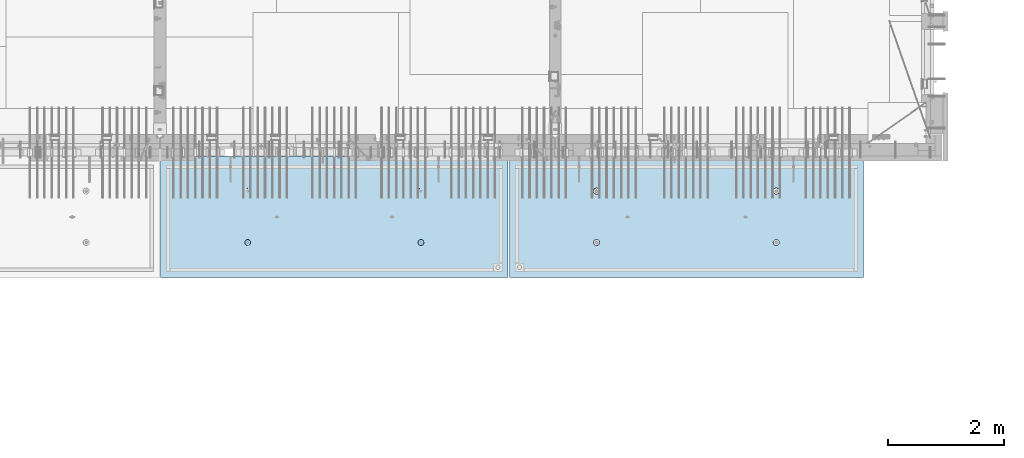
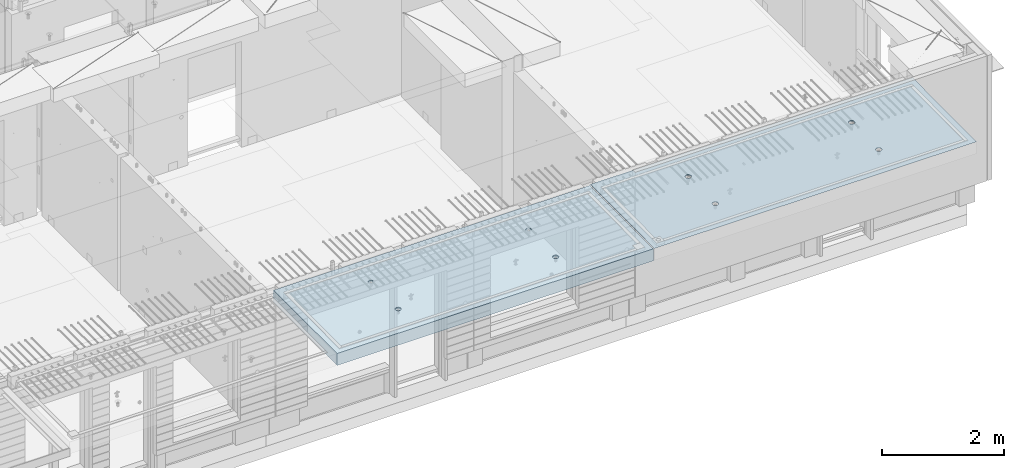
# One storey, part 181 of 325: 2 slabs, 2 elements without a shape of their own.
"""IFC2X3 building model written with IfcOpenShell, lengths in millimetres."""

from ifc_helpers import new_model, si_unit, frame, origin_with_axes, place, context, subcontext, project, spatial, faceted_brep, material, type_object, element, aggregate, save


model = new_model("IFC2X3")

# Units and contexts
model_context = context("Model", 3, precision=1e-05, world=origin_with_axes())
body_context = subcontext(model_context, "Body", "Model", "MODEL_VIEW")
ifc_project = project(units=[si_unit("LENGTHUNIT", "METRE", prefix="MILLI"), si_unit("AREAUNIT", "SQUARE_METRE"), si_unit("VOLUMEUNIT", "CUBIC_METRE"), si_unit("MASSUNIT", "GRAM", prefix="KILO"), si_unit("TIMEUNIT", "SECOND"), si_unit("PLANEANGLEUNIT", "RADIAN"), si_unit("SOLIDANGLEUNIT", "STERADIAN"), si_unit("THERMODYNAMICTEMPERATUREUNIT", "DEGREE_CELSIUS"), si_unit("LUMINOUSINTENSITYUNIT", "LUMEN")], contexts=[model_context])

# Site, building, storey
site_placement = place(None, origin_with_axes())
site = spatial("IfcSite", under=ifc_project, at=site_placement, CompositionType="ELEMENT")
building_placement = place(site_placement, origin_with_axes())
building = spatial("IfcBuilding", under=site, at=building_placement, CompositionType="ELEMENT")
storey_placement = place(building_placement, origin_with_axes())
storey = spatial("IfcBuildingStorey", under=building, at=storey_placement, Name="1", CompositionType="ELEMENT", Elevation=0.0)

# Assembly, slab
assembly_1_placement = place(storey_placement, origin_with_axes())
assembly_1 = element("IfcElementAssembly", 1, at=assembly_1_placement, inside=storey, AssemblyPlace="NOTDEFINED", PredefinedType="REINFORCEMENT_UNIT")
ifc_material = material(Name="CONCRETE/C35/45")
slab_type_1 = type_object("IfcSlabType", PredefinedType="NOTDEFINED")
slab_1_placement = place(assembly_1_placement, frame((33909.9998568133, 7629.99655735226, 84720.0), z_axis=(-1.11800000013248e-06, -0.999999999999375, 0.0), x_axis=(-0.999999999999093, 1.34699999998405e-06, 0.0)))
slab_1 = element("IfcSlab", 2, at=slab_1_placement, type_object=slab_type_1, material=ifc_material, PredefinedType="FLOOR", context=body_context, shape_type="Brep", body=[
    faceted_brep([(4540.5429407651, 4.39872694581572, 1501.06992058926), (4541.14829635528, 10.0, 1500.87322939105), (4548.44394652849, 10.0, 1515.19178906455), (4547.94177529477, 4.5376880098047, 1515.55663695519), (4559.80720044041, 10.0, 1526.55506865745), (4559.44971344555, 4.64790814399021, 1527.04710612474), (4574.1257436257, 10.0, 1533.85075119058), (4573.94028523447, 4.71864591048507, 1534.42153123348), (4589.99797731422, 10.0, 1536.36468442559), (4589.99797663917, 4.74301553473924, 1536.96206902392), (4605.87021668419, 10.0, 1533.85078706184), (4606.05567377324, 4.71864625823218, 1534.42156748629), (4620.18877635769, 10.0, 1526.55513688863), (4620.54626219634, 4.64790880566579, 1527.04717510301), (4631.55205595059, 10.0, 1515.19188297671), (4632.05422627598, 4.53768892097287, 1515.5567319414), (4638.84773848372, 10.0, 1500.87333979142), (4639.45309351355, 4.39872801757883, 1501.0700323201), (4641.36167171873, 10.0, 1485.0011061029), (4642.01569559209, 4.24458991442225, 1485.00110684195), (4638.84777435497, 10.0, 1469.12886673293), (4639.48645790269, 4.09034788147255, 1468.92134666652), (4631.55212418177, 10.0, 1454.81030705943), (4632.10822132771, 3.95111487063696, 1454.40627979329), (4620.18887026985, 10.0, 1443.44702746653), (4620.60028327593, 3.84055859092041, 1442.88076738872), (4605.87032708456, 10.0, 1436.1513449334), (4606.0891136727, 3.76954887632746, 1435.47799164192), (4589.99809339604, 10.0, 1433.63741169839), (4589.99809419923, 3.74507537655882, 1432.92662480936), (4574.12585402606, 10.0, 1436.15130906214), (4573.90706894744, 3.76954852712515, 1435.47795523847), (4559.80729435257, 10.0, 1443.44695923535), (4559.39588258188, 3.84055792690197, 1442.8806981667), (4548.44401475967, 10.0, 1454.81021314727), (4547.88791844284, 3.95111395715503, 1454.40618456334), (4541.14833222653, 10.0, 1469.12875633256), (4540.50964903182, 4.09034680826881, 1468.92123478504), (4538.63439899152, 10.0, 1485.00099002108), (4537.98037499001, 4.24458878673613, 1485.00098928203), (0.0, 10.0, 0.0), (0.0, -10.0, 0.0), (0.000819232023786753, 10.0, 2085.00366210937), (6090.0, 10.0, 1.39971234602854e-09), (6090.0, -10.0, 1.39971234602854e-09), (6090.0009765625, 10.0, 2085.00366210937), (1450.13343574908, -4.39996016312216, 583.805178487186), (1451.68970517172, 10.0, 584.310843019489), (1449.20358093267, 10.0, 600.007498901724), (1447.58488291994, -4.2445425120095, 600.007497072595), (1457.56794425657, -4.54025428339082, 569.17949076172), (1458.90468325205, 10.0, 570.15069079864), (1469.16362510388, -4.65165300057561, 557.566154097598), (1470.14226284945, 10.0, 558.913136598135), (1483.78541952188, -4.72320365252381, 550.106985529351), (1484.30243137612, 10.0, 551.698190519764), (1499.99909477071, -4.74786334385863, 547.536208193364), (1499.99909287695, 10.0, 549.212101755165), (1516.2127641972, -4.72320330067305, 550.107022210277), (1515.69574875919, 10.0, 551.698225994214), (1530.8345417251, -4.65165233150765, 557.566223847243), (1529.85590098004, 10.0, 558.913204074546), (1542.4301962863, -4.54025336292398, 569.179586717545), (1541.09345518054, 10.0, 570.150783671952), (1549.86467170747, -4.39995908172568, 583.805291221456), (1548.30840125891, 10.0, 584.310952198615), (1552.41318790712, -4.24454137573775, 600.00761552858), (1550.79449002351, 10.0, 600.007613699451), (1549.83105300624, -4.08922839167644, 616.199022553535), (1548.30836578447, 10.0, 615.704269581685), (1542.37578967018, -3.94920829200419, 630.796143582923), (1541.09338770413, 10.0, 629.864421802535), (1530.78010888273, -3.83814828256436, 642.374169903326), (1529.85580810672, 10.0, 641.101976003039), (1516.17906941009, -3.76687165064504, 649.804771831361), (1515.69563958006, 10.0, 648.316922081409), (1499.99897631459, -3.74231662515376, 652.364637735232), (1499.99897807923, 10.0, 650.803010846011), (1483.81888899212, -3.76687200104061, 649.804735302227), (1484.30232219699, 10.0, 648.316886606961), (1469.21786628045, -3.83814894927491, 642.374100399286), (1470.14216997614, 10.0, 641.101908526629), (1457.62221161949, -3.94920921009907, 630.796047872702), (1458.90461577564, 10.0, 629.864328929222), (1450.16698124064, -4.08922947161773, 616.198909971055), (1451.68966969727, 10.0, 615.704160402559), (1450.509655854, 4.09040925785666, 1468.92774521603), (1451.1483322995, 10.0, 1469.13526457059), (1448.63439906449, 10.0, 1485.00749825911), (1447.98038215714, 4.24465121529647, 1485.00749752007), (1457.88792425878, 3.95117642574769, 1454.41269697389), (1458.44401483263, 10.0, 1454.8167213853), (1469.39588682837, 3.84062041057041, 1442.8872121491), (1469.80729442553, 10.0, 1443.45346747338), (1483.90707121489, 3.76961102048517, 1435.48447023045), (1484.12585409903, 10.0, 1436.15781730018), (1499.99809427218, 3.74513787325122, 1432.93314014929), (1499.998093469, 10.0, 1433.64391993642), (1516.08911155117, 3.76961136968748, 1435.48450663389), (1515.87032715752, 10.0, 1436.15785317143), (1530.60027917537, 3.8406210745743, 1442.88728137111), (1530.18887034281, 10.0, 1443.45353570456), (1542.1082156577, 3.95117733922962, 1454.41279220383), (1541.55212425473, 10.0, 1454.81681529746), (1549.48645122644, 4.09041033107496, 1468.92785709749), (1548.84777442794, 10.0, 1469.13537497096), (1552.0156885709, 4.24465234298259, 1485.00761507997), (1551.3616717917, 10.0, 1485.00761434093), (1549.45308684185, 4.39879042512621, 1501.07653836665), (1548.84773855669, 10.0, 1500.87984802946), (1542.05422061333, 4.5377513095591, 1515.56323601226), (1541.55205602355, 10.0, 1515.19839121474), (1530.54625810314, 4.64797117923445, 1527.0536776068), (1530.18877643065, 10.0, 1526.56164512666), (1516.05567165627, 4.71870862215292, 1534.42806898436), (1515.87021675715, 10.0, 1533.85729529987), (1499.99797671215, 4.74307789534214, 1536.96857017552), (1499.99797738718, 10.0, 1536.37119266363), (1483.94028749739, 4.71870827439125, 1534.42803273156), (1484.12574369866, 10.0, 1533.85725942862), (1469.44971768469, 4.64797051755886, 1527.05360862854), (1469.80720051337, 10.0, 1526.56157689548), (1457.94178110336, 4.53775039840548, 1515.56314102606), (1458.44394660145, 10.0, 1515.19829730258), (1450.54294758273, 4.39878935334855, 1501.07642663582), (1451.14829642825, 10.0, 1500.87973762909), (4619.85580803376, 10.0, 641.095467765007), (4620.78011297592, -3.83821065611846, 642.367667399533), (4606.17907152706, -3.76693401455123, 649.798270333285), (4605.6956395071, 10.0, 648.310413843377), (4631.09338763116, 10.0, 629.857913564502), (4632.37579533283, -3.94927068060497, 630.789639512066), (4638.30836571149, 10.0, 615.697761343654), (4639.83105967794, -4.08929079922382, 616.192516506986), (4640.79448995054, 10.0, 600.001105461418), (4642.4131949283, -4.24460380429809, 600.001107290555), (4638.30840118594, 10.0, 584.304443960583), (4639.86467838373, -4.40002153132809, 583.798780790478), (4631.09345510758, 10.0, 570.14427543392), (4632.43020195632, -4.54031583151664, 569.173074307006), (4619.85590090707, 10.0, 558.906695836514), (4620.83454582566, -4.65171481517609, 557.559709864858), (4605.69574868622, 10.0, 551.691717756181), (4606.21276631872, -4.72326579401852, 550.100507218302), (4589.99909280399, 10.0, 549.205593517132), (4589.99909469776, -4.74792584055103, 547.529692853434), (4574.30243130315, 10.0, 551.691682281732), (4573.78541725442, -4.72326614588383, 550.10047053737), (4560.14226277649, 10.0, 558.906628360102), (4559.16362085739, -4.65171548424405, 557.559640115202), (4548.90468317908, 10.0, 570.144182560607), (4547.56793844064, -4.54031675198348, 569.172978351166), (4541.68970509875, 10.0, 584.304334781456), (4540.1334289269, -4.40002261272457, 583.798668056191), (4547.6222058109, -3.9492715986853, 630.789543801832), (4559.21786204131, -3.83821132282901, 642.367597895483), (4573.8188867292, -3.76693436496134, 649.798233804147), (4589.99897624161, -3.74237898574211, 652.358136583629), (4537.58487575281, -4.2446049405844, 600.000988834554), (4540.166974423, -4.0892918791651, 616.192403924491), (4589.99897800626, 10.0, 650.796502607977), (4574.30232212402, 10.0, 648.310378368928), (4560.14216990317, 10.0, 641.095400288596), (4548.90461570267, 10.0, 629.85782069119), (4541.6896696243, 10.0, 615.697652164527), (4539.2035808597, 10.0, 600.000990663691)], [[[0, 1, 2, 3]], [[3, 2, 4, 5]], [[5, 4, 6, 7]], [[8, 9, 7, 6]], [[10, 11, 9, 8]], [[12, 13, 11, 10]], [[14, 15, 13, 12]], [[16, 17, 15, 14]], [[18, 19, 17, 16]], [[20, 21, 19, 18]], [[22, 23, 21, 20]], [[24, 25, 23, 22]], [[25, 24, 26, 27]], [[27, 26, 28, 29]], [[29, 28, 30, 31]], [[31, 30, 32, 33]], [[33, 32, 34, 35]], [[35, 34, 36, 37]], [[37, 36, 38, 39]], [[39, 38, 1, 0]], [[40, 41, 42]], [[40, 43, 44, 41]], [[43, 45, 44]], [[46, 47, 48, 49]], [[50, 51, 47, 46]], [[52, 53, 51, 50]], [[54, 55, 53, 52]], [[56, 57, 55, 54]], [[58, 59, 57, 56]], [[59, 58, 60, 61]], [[61, 60, 62, 63]], [[63, 62, 64, 65]], [[65, 64, 66, 67]], [[67, 66, 68, 69]], [[69, 68, 70, 71]], [[71, 70, 72, 73]], [[73, 72, 74, 75]], [[75, 74, 76, 77]], [[78, 79, 77, 76]], [[80, 81, 79, 78]], [[82, 83, 81, 80]], [[84, 85, 83, 82]], [[49, 48, 85, 84]], [[86, 87, 88, 89]], [[90, 91, 87, 86]], [[92, 93, 91, 90]], [[94, 95, 93, 92]], [[96, 97, 95, 94]], [[98, 99, 97, 96]], [[100, 101, 99, 98]], [[101, 100, 102, 103]], [[103, 102, 104, 105]], [[105, 104, 106, 107]], [[107, 106, 108, 109]], [[109, 108, 110, 111]], [[111, 110, 112, 113]], [[113, 112, 114, 115]], [[115, 114, 116, 117]], [[117, 116, 118, 119]], [[120, 121, 119, 118]], [[122, 123, 121, 120]], [[124, 125, 123, 122]], [[89, 88, 125, 124]], [[126, 127, 128, 129]], [[130, 131, 127, 126]], [[132, 133, 131, 130]], [[134, 135, 133, 132]], [[136, 137, 135, 134]], [[138, 139, 137, 136]], [[140, 141, 139, 138]], [[142, 143, 141, 140]], [[143, 142, 144, 145]], [[145, 144, 146, 147]], [[147, 146, 148, 149]], [[149, 148, 150, 151]], [[151, 150, 152, 153]], [[41, 44, 45, 42], [3, 5, 7, 9, 11, 13, 15, 17, 19, 21, 23, 25, 27, 29, 31, 33, 35, 37, 39, 0], [154, 155, 156, 157, 128, 127, 131, 133, 135, 137, 139, 141, 143, 145, 147, 149, 151, 153, 158, 159], [122, 120, 118, 116, 114, 112, 110, 108, 106, 104, 102, 100, 98, 96, 94, 92, 90, 86, 89, 124], [82, 80, 78, 76, 74, 72, 70, 68, 66, 64, 62, 60, 58, 56, 54, 52, 50, 46, 49, 84]], [[129, 128, 157, 160]], [[156, 161, 160, 157]], [[155, 162, 161, 156]], [[154, 163, 162, 155]], [[159, 164, 163, 154]], [[158, 165, 164, 159]], [[153, 152, 165, 158]], [[43, 40, 42, 45], [34, 32, 30, 28, 26, 24, 22, 20, 18, 16, 14, 12, 10, 8, 6, 4, 2, 1, 38, 36], [150, 148, 146, 144, 142, 140, 138, 136, 134, 132, 130, 126, 129, 160, 161, 162, 163, 164, 165, 152], [91, 93, 95, 97, 99, 101, 103, 105, 107, 109, 111, 113, 115, 117, 119, 121, 123, 125, 88, 87], [51, 53, 55, 57, 59, 61, 63, 65, 67, 69, 71, 73, 75, 77, 79, 81, 83, 85, 48, 47]]]),
])
aggregate(assembly_1, [slab_1])

assembly_2_placement = place(storey_placement, origin_with_axes())
assembly_2 = element("IfcElementAssembly", 3, at=assembly_2_placement, inside=storey, AssemblyPlace="NOTDEFINED", PredefinedType="REINFORCEMENT_UNIT")
slab_type_2 = type_object("IfcSlabType", PredefinedType="NOTDEFINED")
slab_2_placement = place(assembly_2_placement, frame((27799.9998568133, 7629.99655735226, 84590.0), z_axis=(-1.11800000013248e-06, -0.999999999999375, 0.0), x_axis=(-0.999999999999093, 1.34699999998405e-06, 0.0)))
slab_2 = element("IfcSlab", 4, at=slab_2_placement, type_object=slab_type_2, material=ifc_material, PredefinedType="FLOOR", context=body_context, shape_type="Brep", body=[
    faceted_brep([(4464.54840508898, -115.0, 647.555217913627), (4450.61000036748, -115.0, 640.453225774507), (4439.54842599525, -115.0, 629.391625938503), (4432.44646594236, -115.0, 615.453204868262), (4429.99930954105, -115.0, 600.002352332828), (4432.44650151022, -115.0, 584.551505430789), (4439.54849364933, -115.0, 570.613100709295), (4450.61009348534, -115.0, 559.551526337066), (4464.54851455558, -115.0, 552.449566284174), (4479.99936709102, -115.0, 550.002409882861), (4495.45021399306, -115.0, 552.449601852029), (4509.38861871455, -115.0, 559.551593991148), (4520.45019308678, -115.0, 570.613193827152), (4527.55215313967, -115.0, 584.551614897394), (4529.99930954098, -115.0, 600.002467432828), (4527.55211757181, -115.0, 615.453314334867), (4520.4501254327, -115.0, 629.39171905636), (4509.38852559669, -115.0, 640.453293428589), (4495.45010452645, -115.0, 647.555253481482), (4479.99925199102, -115.0, 650.002409882794), (4439.08882528693, -120.0, 570.279131286869), (4431.90612869169, -120.0, 584.375926971106), (4450.27612512107, -120.0, 559.091857205865), (4464.37293733984, -120.0, 551.909193061462), (4479.99936774499, -120.0, 549.43422806468), (4495.62579245274, -120.0, 551.909229033498), (4509.72258813697, -120.0, 559.091925628744), (4520.90986221798, -120.0, 570.279225462882), (4528.09252636238, -120.0, 584.37603768165), (4530.56749135916, -120.0, 600.002468086805), (4528.09249039035, -120.0, 615.628892794549), (4520.9097937951, -120.0, 629.725688478787), (4509.72249396096, -120.0, 640.912962559792), (4495.6256817422, -120.0, 648.095626704194), (4479.99925133704, -120.0, 650.570591700976), (4464.3728266293, -120.0, 648.095590732158), (4450.27603094506, -120.0, 640.912894136913), (4439.08875686405, -120.0, 629.725594302773), (4431.90609271965, -120.0, 615.628782084005), (4429.43112772287, -120.0, 600.002351678851), (0.000819232023786753, -120.0, 2085.00366210938), (5980.0009765625, -120.0, 2085.00366210937), (5980.0009765625, 120.0, 2085.00366210937), (0.000819232023786753, 120.0, 2085.00366210938), (5980.0, -120.0, -2.4019755073823e-09), (5980.0, 120.0, -2.4019755073823e-09), (-7.27595761418343e-12, -120.0, -9.09494701772928e-13), (-7.27595761418343e-12, 120.0, -9.09494701772928e-13), (1515.44890870648, -105.0, 1437.44477976918), (1529.38731342797, -105.0, 1444.5467719083), (1540.4488878002, -105.0, 1455.60837174431), (1547.55084785309, -105.0, 1469.54679281455), (1549.99800425441, -105.0, 1484.99764534998), (1547.55081228524, -105.0, 1500.44849225202), (1540.44882014612, -105.0, 1514.38689697351), (1529.38722031012, -105.0, 1525.44847134574), (1515.44879923988, -105.0, 1532.55043139864), (1499.99794670444, -105.0, 1534.99758779995), (1484.5470998024, -105.0, 1532.55039583078), (1470.60869508091, -105.0, 1525.44840369166), (1459.54712070868, -105.0, 1514.38680385566), (1452.44516065579, -105.0, 1500.44838278542), (1449.99800425447, -105.0, 1484.99753024998), (1452.44519622364, -105.0, 1469.54668334794), (1459.54718836276, -105.0, 1455.60827862645), (1470.60878819877, -105.0, 1444.54670425422), (1484.547209269, -105.0, 1437.44474420133), (1499.99806180444, -105.0, 1434.99758780001), (1450.82407776805, -120.0, 1469.01994796889), (1448.29345879993, -120.0, 1484.99752828805), (1458.16818327555, -120.0, 1454.60637035917), (1469.60688310596, -120.0, 1443.16769686061), (1484.02047762178, -120.0, 1435.82362453319), (1499.99806376637, -120.0, 1433.29304234547), (1515.97564408552, -120.0, 1435.82366131359), (1530.38922169525, -120.0, 1443.16776682109), (1541.82789519381, -120.0, 1454.6064666515), (1549.17196752123, -120.0, 1469.02006116732), (1551.70254970895, -120.0, 1484.99764731191), (1549.17193074083, -120.0, 1500.97522763107), (1541.82782523334, -120.0, 1515.38880524079), (1530.38912540293, -120.0, 1526.82747873935), (1515.9755308871, -120.0, 1534.17155106677), (1499.99794474251, -120.0, 1536.70213325449), (1484.02036442336, -120.0, 1534.17151428637), (1469.60678681363, -120.0, 1526.82740877888), (1458.16811331507, -120.0, 1515.38870894846), (1450.82404098765, -120.0, 1500.97511443265), (1484.54840517324, -115.0, 647.55178787166), (1470.61000045175, -115.0, 640.44979573254), (1459.54842607952, -115.0, 629.388195896537), (1452.44646602663, -115.0, 615.449774826296), (1449.99930962532, -115.0, 599.998922290862), (1452.44650159449, -115.0, 584.548075388822), (1459.5484937336, -115.0, 570.609670667329), (1470.61009356961, -115.0, 559.5480962951), (1484.54851463985, -115.0, 552.446136242207), (1499.99936717528, -115.0, 549.998979840894), (1515.45021407733, -115.0, 552.446171810063), (1529.38861879882, -115.0, 559.548163949182), (1540.45019317105, -115.0, 570.609763785185), (1547.55215322394, -115.0, 584.548184855427), (1549.99930962525, -115.0, 599.999037390861), (1547.55211765608, -115.0, 615.449884292901), (1540.45012551697, -115.0, 629.388289014393), (1529.38852568096, -115.0, 640.449863386622), (1515.45010461072, -115.0, 647.551823439516), (1499.99925207528, -115.0, 649.998979840828), (1451.90612877595, -120.0, 584.37249692914), (1449.43112780714, -120.0, 599.998921636884), (1459.0888253712, -120.0, 570.275701244902), (1470.27612520534, -120.0, 559.088427163899), (1484.3729374241, -120.0, 551.905763019496), (1499.99936782926, -120.0, 549.430798022713), (1515.62579253701, -120.0, 551.905798991532), (1529.72258822124, -120.0, 559.088495586778), (1540.90986230225, -120.0, 570.275795420916), (1548.09252644665, -120.0, 584.372607639683), (1550.56749144343, -120.0, 599.999038044839), (1548.09249047462, -120.0, 615.625462752582), (1540.90979387937, -120.0, 629.72225843682), (1529.72249404523, -120.0, 640.909532517825), (1515.62568182647, -120.0, 648.092196662227), (1499.9992514213, -120.0, 650.56716165901), (1484.37282671356, -120.0, 648.092160690191), (1470.27603102933, -120.0, 640.909464094946), (1459.08875694832, -120.0, 629.722164260806), (1451.90609280392, -120.0, 615.625352042039), (4495.44890862221, -105.0, 1437.44820981115), (4509.3873133437, -105.0, 1444.55020195027), (4520.44888771593, -105.0, 1455.61180178627), (4527.55084776882, -105.0, 1469.55022285651), (4529.99800417014, -105.0, 1485.00107539195), (4527.55081220097, -105.0, 1500.45192229399), (4520.44882006185, -105.0, 1514.39032701548), (4509.38722022585, -105.0, 1525.45190138771), (4495.44879915561, -105.0, 1532.5538614406), (4479.99794662017, -105.0, 1535.00101784192), (4464.54709971813, -105.0, 1532.55382587275), (4450.60869499664, -105.0, 1525.45183373363), (4439.54712062441, -105.0, 1514.39023389763), (4432.44516057152, -105.0, 1500.45181282738), (4429.9980041702, -105.0, 1485.00096029195), (4432.44519613937, -105.0, 1469.55011338991), (4439.54718827849, -105.0, 1455.61170866842), (4450.6087881145, -105.0, 1444.55013429619), (4464.54720918474, -105.0, 1437.44817424329), (4479.99806172017, -105.0, 1435.00101784198), (4430.82407768378, -120.0, 1469.02337801086), (4428.29345871566, -120.0, 1485.00095833002), (4438.16818319128, -120.0, 1454.60980040114), (4449.60688302169, -120.0, 1443.17112690258), (4464.02047753751, -120.0, 1435.82705457516), (4479.99806368211, -120.0, 1433.29647238744), (4495.97564400126, -120.0, 1435.82709135556), (4510.38922161098, -120.0, 1443.17119686305), (4521.82789510954, -120.0, 1454.60989669347), (4529.17196743696, -120.0, 1469.02349120928), (4531.70254962468, -120.0, 1485.00107735388), (4529.17193065656, -120.0, 1500.97865767303), (4521.82782514907, -120.0, 1515.39223528276), (4510.38912531866, -120.0, 1526.83090878132), (4495.97553080284, -120.0, 1534.17498110874), (4479.99794465824, -120.0, 1536.70556329646), (4464.02036433909, -120.0, 1534.17494432834), (4449.60678672936, -120.0, 1526.83083882084), (4438.1681132308, -120.0, 1515.39213899043), (4430.82404090338, -120.0, 1500.97854447461)], [[[0, 1, 2, 3, 4, 5, 6, 7, 8, 9, 10, 11, 12, 13, 14, 15, 16, 17, 18, 19]], [[20, 6, 5, 21]], [[22, 7, 6, 20]], [[23, 8, 7, 22]], [[24, 9, 8, 23]], [[25, 10, 9, 24]], [[26, 11, 10, 25]], [[27, 12, 11, 26]], [[28, 13, 12, 27]], [[29, 14, 13, 28]], [[30, 15, 14, 29]], [[31, 16, 15, 30]], [[32, 17, 16, 31]], [[33, 18, 17, 32]], [[34, 19, 18, 33]], [[35, 0, 19, 34]], [[36, 1, 0, 35]], [[37, 2, 1, 36]], [[38, 3, 2, 37]], [[39, 4, 3, 38]], [[21, 5, 4, 39]], [[40, 41, 42, 43]], [[41, 44, 45, 42]], [[44, 46, 47, 45]], [[42, 45, 47, 43]], [[46, 40, 43, 47]], [[48, 49, 50, 51, 52, 53, 54, 55, 56, 57, 58, 59, 60, 61, 62, 63, 64, 65, 66, 67]], [[68, 63, 62, 69]], [[70, 64, 63, 68]], [[71, 65, 64, 70]], [[72, 66, 65, 71]], [[73, 67, 66, 72]], [[74, 48, 67, 73]], [[75, 49, 48, 74]], [[76, 50, 49, 75]], [[77, 51, 50, 76]], [[78, 52, 51, 77]], [[79, 53, 52, 78]], [[80, 54, 53, 79]], [[81, 55, 54, 80]], [[82, 56, 55, 81]], [[83, 57, 56, 82]], [[84, 58, 57, 83]], [[85, 59, 58, 84]], [[86, 60, 59, 85]], [[87, 61, 60, 86]], [[69, 62, 61, 87]], [[88, 89, 90, 91, 92, 93, 94, 95, 96, 97, 98, 99, 100, 101, 102, 103, 104, 105, 106, 107]], [[108, 93, 92, 109]], [[110, 94, 93, 108]], [[111, 95, 94, 110]], [[112, 96, 95, 111]], [[113, 97, 96, 112]], [[114, 98, 97, 113]], [[115, 99, 98, 114]], [[116, 100, 99, 115]], [[117, 101, 100, 116]], [[118, 102, 101, 117]], [[119, 103, 102, 118]], [[120, 104, 103, 119]], [[121, 105, 104, 120]], [[122, 106, 105, 121]], [[123, 107, 106, 122]], [[124, 88, 107, 123]], [[125, 89, 88, 124]], [[126, 90, 89, 125]], [[127, 91, 90, 126]], [[109, 92, 91, 127]], [[128, 129, 130, 131, 132, 133, 134, 135, 136, 137, 138, 139, 140, 141, 142, 143, 144, 145, 146, 147]], [[148, 143, 142, 149]], [[150, 144, 143, 148]], [[151, 145, 144, 150]], [[152, 146, 145, 151]], [[153, 147, 146, 152]], [[154, 128, 147, 153]], [[155, 129, 128, 154]], [[156, 130, 129, 155]], [[157, 131, 130, 156]], [[158, 132, 131, 157]], [[159, 133, 132, 158]], [[160, 134, 133, 159]], [[161, 135, 134, 160]], [[162, 136, 135, 161]], [[163, 137, 136, 162]], [[164, 138, 137, 163]], [[165, 139, 138, 164]], [[166, 140, 139, 165]], [[167, 141, 140, 166]], [[149, 142, 141, 167]], [[44, 41, 40, 46], [37, 36, 35, 34, 33, 32, 31, 30, 29, 28, 27, 26, 25, 24, 23, 22, 20, 21, 39, 38], [166, 165, 164, 163, 162, 161, 160, 159, 158, 157, 156, 155, 154, 153, 152, 151, 150, 148, 149, 167], [126, 125, 124, 123, 122, 121, 120, 119, 118, 117, 116, 115, 114, 113, 112, 111, 110, 108, 109, 127], [86, 85, 84, 83, 82, 81, 80, 79, 78, 77, 76, 75, 74, 73, 72, 71, 70, 68, 69, 87]]]),
])
aggregate(assembly_2, [slab_2])

save(model, "model.ifc")
